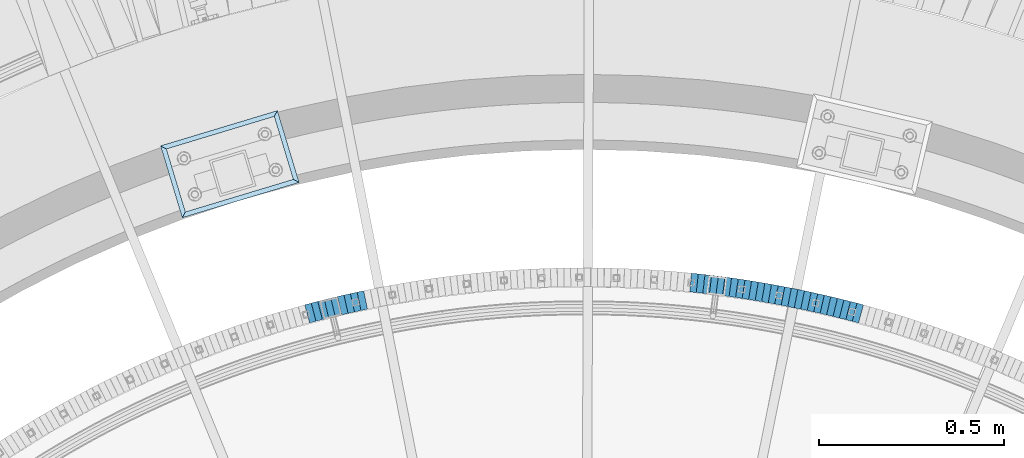
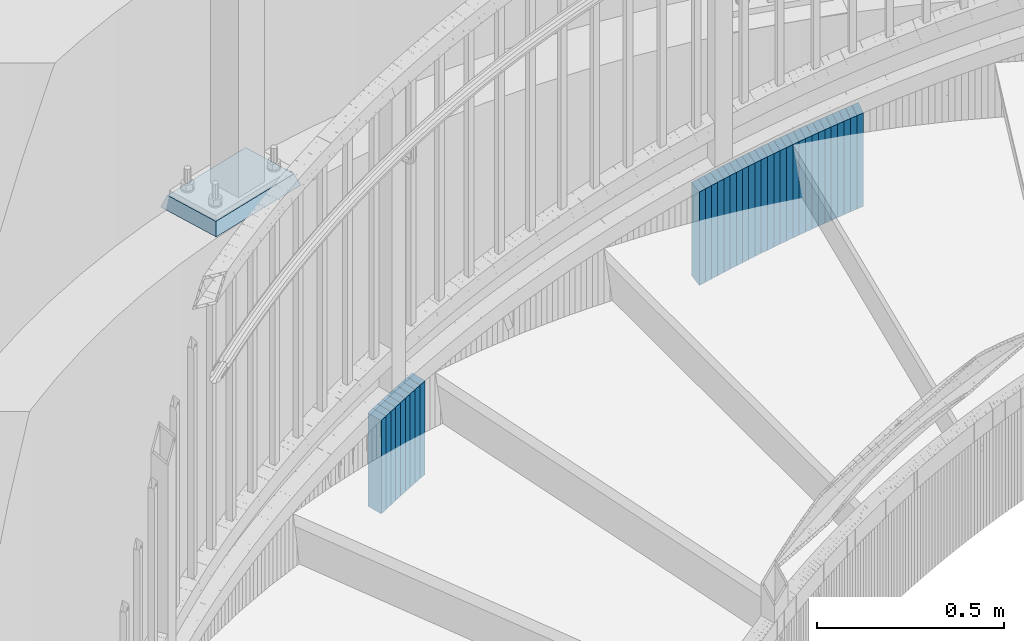
# One storey, part 917 of 975: 36 plates.
"""IFC2X3 building model written with IfcOpenShell, lengths in millimetres."""

from ifc_helpers import new_model, si_unit, frame, origin_with_axes, place, context, subcontext, project, spatial, faceted_brep, material, type_object, element, save


model = new_model("IFC2X3")

# Units and contexts
model_context = context("Model", 3, precision=1e-05, world=origin_with_axes())
body_context = subcontext(model_context, "Body", "Model", "MODEL_VIEW")
ifc_project = project(units=[si_unit("LENGTHUNIT", "METRE", prefix="MILLI"), si_unit("AREAUNIT", "SQUARE_METRE"), si_unit("VOLUMEUNIT", "CUBIC_METRE"), si_unit("MASSUNIT", "GRAM", prefix="KILO"), si_unit("TIMEUNIT", "SECOND"), si_unit("PLANEANGLEUNIT", "RADIAN"), si_unit("SOLIDANGLEUNIT", "STERADIAN"), si_unit("THERMODYNAMICTEMPERATUREUNIT", "DEGREE_CELSIUS"), si_unit("LUMINOUSINTENSITYUNIT", "LUMEN")], contexts=[model_context])

# Site, building, storey
site_placement = place(None, origin_with_axes())
site = spatial("IfcSite", under=ifc_project, at=site_placement, CompositionType="ELEMENT")
building_placement = place(site_placement, origin_with_axes())
building = spatial("IfcBuilding", under=site, at=building_placement, Name="Undefined", CompositionType="ELEMENT")
storey_placement = place(building_placement, origin_with_axes())
storey = spatial("IfcBuildingStorey", under=building, at=storey_placement, Name="Undefined", CompositionType="ELEMENT", Elevation=0.0)

# Plates
ifc_material_1 = material(Name="STEEL/A36")
plate_type_1 = type_object("IfcPlateType", PredefinedType="NOTDEFINED")
plate_1_placement = place(storey_placement, frame((35466.359514086, 6179.51815033245, 1301.99999999174), z_axis=(0.966048244824465, -0.258361739953056, 0.0), x_axis=(0.0, 0.0, -1.0)))
element("IfcPlate", 1, at=plate_1_placement, inside=storey, type_object=plate_type_1, material=ifc_material_1, Name="WALL", context=body_context, shape_type="Brep", body=[
    faceted_brep([(0.0, -25.3999999999724, -1.81898940354586e-11), (-5.69999980926514, -25.4000000000378, 17.8044929504049), (-5.69999980926514, 25.4000000000233, 17.8044929504613), (0.0, 25.3999999999869, 1.45519152283669e-11), (299.100006103516, -25.4000000000378, 17.8044929504049), (299.100006103516, 25.4000000000233, 17.8044929504613), (304.799987792969, -25.3999999999724, -1.81898940354586e-11), (304.799987792969, 25.3999999999869, 1.45519152283669e-11)], [[[0, 1, 2, 3]], [[1, 4, 5, 2]], [[4, 6, 7, 5]], [[6, 0, 3, 7]], [[5, 7, 3, 2]], [[6, 4, 1, 0]]]),
])
plate_2_placement = place(storey_placement, frame((35448.8912875998, 6184.06252434382, 1296.29999999174), z_axis=(0.967795253177515, -0.251738650046175, 0.0), x_axis=(0.0, 0.0, -1.0)))
element("IfcPlate", 2, at=plate_2_placement, inside=storey, type_object=plate_type_1, material=ifc_material_1, Name="WALL", context=body_context, shape_type="Brep", body=[
    faceted_brep([(0.0, -25.3999999999724, -1.81898940354586e-11), (-5.69999980926514, -25.4000000000233, 17.8807163238162), (-5.69999980926514, 25.400000000096, 17.8807163239253), (0.0, 25.3999999999869, 1.45519152283669e-11), (299.100006103516, -25.4000000000233, 17.8807163238162), (299.100006103516, 25.400000000096, 17.8807163239253), (304.799987792969, -25.3999999999724, -1.81898940354586e-11), (304.799987792969, 25.3999999999869, 1.45519152283669e-11)], [[[0, 1, 2, 3]], [[1, 4, 5, 2]], [[4, 6, 7, 5]], [[6, 0, 3, 7]], [[5, 7, 3, 2]], [[6, 4, 1, 0]]]),
])
plate_3_placement = place(storey_placement, frame((35431.1908193809, 6188.43872638545, 1290.49999999174), z_axis=(0.970795333552335, -0.23990919188937, 0.0), x_axis=(0.0, 0.0, -1.0)))
element("IfcPlate", 3, at=plate_3_placement, inside=storey, type_object=plate_type_1, material=ifc_material_1, Name="WALL", context=body_context, shape_type="Brep", body=[
    faceted_brep([(0.0, -25.3999999999724, -1.81898940354586e-11), (-5.80000019073486, -25.3999999999724, 17.9212169647508), (-5.80000019073486, 25.399999999885, 17.9212169646526), (0.0, 25.3999999999869, 1.45519152283669e-11), (299.0, -25.3999999999724, 17.9212169647508), (299.0, 25.399999999885, 17.9212169646526), (304.799987792969, -25.3999999999724, -1.81898940354586e-11), (304.799987792969, 25.3999999999869, 1.45519152283669e-11)], [[[0, 1, 2, 3]], [[1, 4, 5, 2]], [[4, 6, 7, 5]], [[6, 0, 3, 7]], [[5, 7, 3, 2]], [[6, 4, 1, 0]]]),
])
plate_4_placement = place(storey_placement, frame((35413.9239990979, 6192.73050310389, 1284.79999999174), z_axis=(0.970471582358486, -0.241215480089104, 0.0), x_axis=(0.0, 0.0, -1.0)))
element("IfcPlate", 4, at=plate_4_placement, inside=storey, type_object=plate_type_1, material=ifc_material_1, Name="WALL", context=body_context, shape_type="Brep", body=[
    faceted_brep([(0.0, -25.3999999999724, -1.81898940354586e-11), (-5.69999980926514, -25.4000000000524, 17.8331146239652), (-5.69999980926514, 25.4000000000742, 17.8331146240998), (0.0, 25.3999999999869, 1.45519152283669e-11), (299.100006103516, -25.4000000000524, 17.8331146239652), (299.100006103516, 25.4000000000742, 17.8331146240998), (304.799987792969, -25.3999999999724, -1.81898940354586e-11), (304.799987792969, 25.3999999999869, 1.45519152283669e-11)], [[[0, 1, 2, 3]], [[1, 4, 5, 2]], [[4, 6, 7, 5]], [[6, 0, 3, 7]], [[5, 7, 3, 2]], [[6, 4, 1, 0]]]),
])
plate_5_placement = place(storey_placement, frame((35396.3569954345, 6196.97141301187, 1279.09999999174), z_axis=(0.972082208620478, -0.234640532908391, 0.0), x_axis=(0.0, 0.0, -1.0)))
element("IfcPlate", 5, at=plate_5_placement, inside=storey, type_object=plate_type_1, material=ifc_material_1, Name="WALL", context=body_context, shape_type="Brep", body=[
    faceted_brep([(0.0, -25.3999999999724, -1.81898940354586e-11), (-5.69999980926514, -25.3999999999578, 17.9047489166387), (-5.69999980926514, 25.3999999999069, 17.9047489165732), (0.0, 25.3999999999869, 1.45519152283669e-11), (299.100006103516, -25.3999999999578, 17.9047489166387), (299.100006103516, 25.3999999999069, 17.9047489165732), (304.799987792969, -25.3999999999724, -1.81898940354586e-11), (304.799987792969, 25.3999999999869, 1.45519152283669e-11)], [[[0, 1, 2, 3]], [[1, 4, 5, 2]], [[4, 6, 7, 5]], [[6, 0, 3, 7]], [[5, 7, 3, 2]], [[6, 4, 1, 0]]]),
])
plate_6_placement = place(storey_placement, frame((35378.5568758462, 6201.04193098155, 1273.29999999174), z_axis=(0.974858506702201, -0.222824800931933, 0.0), x_axis=(0.0, 0.0, -1.0)))
element("IfcPlate", 6, at=plate_6_placement, inside=storey, type_object=plate_type_1, material=ifc_material_1, Name="WALL", context=body_context, shape_type="Brep", body=[
    faceted_brep([(0.0, -25.3999999999724, -1.81898940354586e-11), (-5.80000019073486, -25.4000000000196, 17.9513225554401), (-5.80000019073486, 25.3999999999851, 17.9513225555565), (0.0, 25.3999999999869, 1.45519152283669e-11), (299.0, -25.4000000000196, 17.9513225554401), (299.0, 25.3999999999851, 17.9513225555565), (304.799987792969, -25.3999999999724, -1.81898940354586e-11), (304.799987792969, 25.3999999999869, 1.45519152283669e-11)], [[[0, 1, 2, 3]], [[1, 4, 5, 2]], [[4, 6, 7, 5]], [[6, 0, 3, 7]], [[5, 7, 3, 2]], [[6, 4, 1, 0]]]),
])
plate_7_placement = place(storey_placement, frame((35361.0523969051, 6204.96558016644, 1267.59999999174), z_axis=(0.975789576997609, -0.218711456999464, 0.0), x_axis=(0.0, 0.0, -1.0)))
element("IfcPlate", 7, at=plate_7_placement, inside=storey, type_object=plate_type_1, material=ifc_material_1, Name="WALL", context=body_context, shape_type="Brep", body=[
    faceted_brep([(0.0, -25.3999999999724, -1.81898940354586e-11), (-5.69999980926514, -25.4000000000524, 17.8331146239652), (-5.69999980926514, 25.4000000000742, 17.8331146240998), (0.0, 25.3999999999869, 1.45519152283669e-11), (299.100006103516, -25.4000000000524, 17.8331146239652), (299.100006103516, 25.4000000000742, 17.8331146240998), (304.799987792969, -25.3999999999724, -1.81898940354586e-11), (304.799987792969, 25.3999999999869, 1.45519152283669e-11)], [[[0, 1, 2, 3]], [[1, 4, 5, 2]], [[4, 6, 7, 5]], [[6, 0, 3, 7]], [[5, 7, 3, 2]], [[6, 4, 1, 0]]]),
])
plate_8_placement = place(storey_placement, frame((35343.5221586185, 6208.87233834774, 1261.79999999174), z_axis=(0.976055647129105, -0.217520973028771, 0.0), x_axis=(0.0, 0.0, -1.0)))
element("IfcPlate", 8, at=plate_8_placement, inside=storey, type_object=plate_type_1, material=ifc_material_1, Name="WALL", context=body_context, shape_type="Brep", body=[
    faceted_brep([(0.0, -25.3999999999724, -1.81898940354586e-11), (-5.80000019073486, -25.3999999998778, 17.9254016876821), (-5.80000019073486, 25.3999999999651, 17.9254016876057), (0.0, 25.3999999999869, 1.45519152283669e-11), (299.0, -25.3999999998778, 17.9254016876821), (299.0, 25.3999999999651, 17.9254016876057), (304.799987792969, -25.3999999999724, -1.81898940354586e-11), (304.799987792969, 25.3999999999869, 1.45519152283669e-11)], [[[0, 1, 2, 3]], [[1, 4, 5, 2]], [[4, 6, 7, 5]], [[6, 0, 3, 7]], [[5, 7, 3, 2]], [[6, 4, 1, 0]]]),
])
plate_9_placement = place(storey_placement, frame((35325.6226741571, 6212.63718690472, 1256.09999999174), z_axis=(0.978608739939518, -0.205730245987284, 0.0), x_axis=(0.0, 0.0, -1.0)))
element("IfcPlate", 9, at=plate_9_placement, inside=storey, type_object=plate_type_1, material=ifc_material_1, Name="WALL", context=body_context, shape_type="Brep", body=[
    faceted_brep([(0.0, -25.3999999999724, -1.81898940354586e-11), (-5.69999980926514, -25.3999999999141, 17.9836044311924), (-5.69999980926514, 25.3999999999432, 17.983604431116), (0.0, 25.3999999999869, 1.45519152283669e-11), (299.100006103516, -25.3999999999141, 17.9836044311924), (299.100006103516, 25.3999999999432, 17.983604431116), (304.799987792969, -25.3999999999724, -1.81898940354586e-11), (304.799987792969, 25.3999999999869, 1.45519152283669e-11)], [[[0, 1, 2, 3]], [[1, 4, 5, 2]], [[4, 6, 7, 5]], [[6, 0, 3, 7]], [[5, 7, 3, 2]], [[6, 4, 1, 0]]]),
])
plate_10_placement = place(storey_placement, frame((35308.0150987024, 6216.25955934488, 1250.39999999174), z_axis=(0.979489544723104, -0.201494991943039, 0.0), x_axis=(0.0, 0.0, -1.0)))
element("IfcPlate", 10, at=plate_10_placement, inside=storey, type_object=plate_type_1, material=ifc_material_1, Name="WALL", context=body_context, shape_type="Brep", body=[
    faceted_brep([(0.0, -25.3999999999724, -1.81898940354586e-11), (-5.69999980926514, -25.4000000000524, 17.8734436034756), (-5.69999980926514, 25.4000000000888, 17.8734436035884), (0.0, 25.3999999999869, 1.45519152283669e-11), (299.100006103516, -25.4000000000524, 17.8734436034756), (299.100006103516, 25.4000000000888, 17.8734436035884), (304.799987792969, -25.3999999999724, -1.81898940354586e-11), (304.799987792969, 25.3999999999869, 1.45519152283669e-11)], [[[0, 1, 2, 3]], [[1, 4, 5, 2]], [[4, 6, 7, 5]], [[6, 0, 3, 7]], [[5, 7, 3, 2]], [[6, 4, 1, 0]]]),
])
plate_11_placement = place(storey_placement, frame((35290.2512522868, 6219.79270328996, 1244.59999999174), z_axis=(0.980794424500948, -0.195044345900756, 0.0), x_axis=(0.0, 0.0, -1.0)))
element("IfcPlate", 11, at=plate_11_placement, inside=storey, type_object=plate_type_1, material=ifc_material_1, Name="WALL", context=body_context, shape_type="Brep", body=[
    faceted_brep([(0.0, -25.3999999999724, -1.81898940354586e-11), (-5.80000019073486, -25.3999999999869, 17.9387855530222), (-5.80000019073486, 25.3999999999469, 17.9387855528548), (0.0, 25.3999999999869, 1.45519152283669e-11), (299.0, -25.3999999999869, 17.9387855530222), (299.0, 25.3999999999469, 17.9387855528548), (304.799987792969, -25.3999999999724, -1.81898940354586e-11), (304.799987792969, 25.3999999999869, 1.45519152283669e-11)], [[[0, 1, 2, 3]], [[1, 4, 5, 2]], [[4, 6, 7, 5]], [[6, 0, 3, 7]], [[5, 7, 3, 2]], [[6, 4, 1, 0]]]),
])
plate_12_placement = place(storey_placement, frame((35272.5148702956, 6223.21943705456, 1238.79999999174), z_axis=(0.98184693485788, -0.189674975972545, 0.0), x_axis=(0.0, 0.0, -1.0)))
element("IfcPlate", 12, at=plate_12_placement, inside=storey, type_object=plate_type_1, material=ifc_material_1, Name="WALL", context=body_context, shape_type="Brep", body=[
    faceted_brep([(0.0, -25.3999999999724, -1.81898940354586e-11), (-5.80000019073486, -25.3999999998778, 17.9254016876821), (-5.80000019073486, 25.3999999999651, 17.9254016876057), (0.0, 25.3999999999869, 1.45519152283669e-11), (299.0, -25.3999999998778, 17.9254016876821), (299.0, 25.3999999999651, 17.9254016876057), (304.799987792969, -25.3999999999724, -1.81898940354586e-11), (304.799987792969, 25.3999999999869, 1.45519152283669e-11)], [[[0, 1, 2, 3]], [[1, 4, 5, 2]], [[4, 6, 7, 5]], [[6, 0, 3, 7]], [[5, 7, 3, 2]], [[6, 4, 1, 0]]]),
])
plate_13_placement = place(storey_placement, frame((35254.9148703005, 6226.61943705608, 1233.09999999174), z_axis=(0.98184693485788, -0.189674975972545, 0.0), x_axis=(0.0, 0.0, -1.0)))
element("IfcPlate", 13, at=plate_13_placement, inside=storey, type_object=plate_type_1, material=ifc_material_1, Name="WALL", context=body_context, shape_type="Brep", body=[
    faceted_brep([(0.0, -25.3999999999724, -1.81898940354586e-11), (-5.69999980926514, -25.3999999999942, 17.9287471771386), (-5.69999980926514, 25.3999999999796, 17.9287471770876), (0.0, 25.3999999999869, 1.45519152283669e-11), (299.100006103516, -25.3999999999942, 17.9287471771386), (299.100006103516, 25.3999999999796, 17.9287471770876), (304.799987792969, -25.3999999999724, -1.81898940354586e-11), (304.799987792969, 25.3999999999869, 1.45519152283669e-11)], [[[0, 1, 2, 3]], [[1, 4, 5, 2]], [[4, 6, 7, 5]], [[6, 0, 3, 7]], [[5, 7, 3, 2]], [[6, 4, 1, 0]]]),
])
plate_14_placement = place(storey_placement, frame((35237.040816045, 6229.87082062702, 1227.39999999174), z_axis=(0.983869910131907, -0.178885438023984, 0.0), x_axis=(0.0, 0.0, -1.0)))
element("IfcPlate", 14, at=plate_14_placement, inside=storey, type_object=plate_type_1, material=ifc_material_1, Name="WALL", context=body_context, shape_type="Brep", body=[
    faceted_brep([(0.0, -25.3999999999724, -1.81898940354586e-11), (-5.69999980926514, -25.4000000000087, 17.8910598754701), (-5.69999980926514, 25.4000000000087, 17.8910598755028), (0.0, 25.3999999999869, 1.45519152283669e-11), (299.100006103516, -25.4000000000087, 17.8910598754701), (299.100006103516, 25.4000000000087, 17.8910598755028), (304.799987792969, -25.3999999999724, -1.81898940354586e-11), (304.799987792969, 25.3999999999869, 1.45519152283669e-11)], [[[0, 1, 2, 3]], [[1, 4, 5, 2]], [[4, 6, 7, 5]], [[6, 0, 3, 7]], [[5, 7, 3, 2]], [[6, 4, 1, 0]]]),
])
plate_15_placement = place(storey_placement, frame((35219.1790150726, 6232.9996985061, 1221.59999999174), z_axis=(0.985006834489333, -0.172515321085703, 0.0), x_axis=(0.0, 0.0, -1.0)))
element("IfcPlate", 15, at=plate_15_placement, inside=storey, type_object=plate_type_1, material=ifc_material_1, Name="WALL", context=body_context, shape_type="Brep", body=[
    faceted_brep([(0.0, -25.3999999999724, -1.81898940354586e-11), (-5.80000019073486, -25.4000000000051, 17.9724788665662), (-5.80000019073486, 25.4000000000196, 17.9724788666281), (0.0, 25.3999999999869, 1.45519152283669e-11), (299.0, -25.4000000000051, 17.9724788665662), (299.0, 25.4000000000196, 17.9724788666281), (304.799987792969, -25.3999999999724, -1.81898940354586e-11), (304.799987792969, 25.3999999999869, 1.45519152283669e-11)], [[[0, 1, 2, 3]], [[1, 4, 5, 2]], [[4, 6, 7, 5]], [[6, 0, 3, 7]], [[5, 7, 3, 2]], [[6, 4, 1, 0]]]),
])
plate_16_placement = place(storey_placement, frame((35201.4651126618, 6236.01938049812, 1215.89999999174), z_axis=(0.985781716087097, -0.168030974014847, 0.0), x_axis=(0.0, 0.0, -1.0)))
element("IfcPlate", 16, at=plate_16_placement, inside=storey, type_object=plate_type_1, material=ifc_material_1, Name="WALL", context=body_context, shape_type="Brep", body=[
    faceted_brep([(0.0, -25.3999999999724, -1.81898940354586e-11), (-5.69999980926514, -25.3999999999578, 17.853290557905), (-5.69999980926514, 25.4000000000124, 17.8532905578759), (0.0, 25.3999999999869, 1.45519152283669e-11), (299.100006103516, -25.3999999999578, 17.853290557905), (299.100006103516, 25.4000000000124, 17.8532905578759), (304.799987792969, -25.3999999999724, -1.81898940354586e-11), (304.799987792969, 25.3999999999869, 1.45519152283669e-11)], [[[0, 1, 2, 3]], [[1, 4, 5, 2]], [[4, 6, 7, 5]], [[6, 0, 3, 7]], [[5, 7, 3, 2]], [[6, 4, 1, 0]]]),
])
plate_17_placement = place(storey_placement, frame((35183.6039508099, 6238.94631812282, 1210.09999999174), z_axis=(0.986842252457648, -0.161686019074982, 0.0), x_axis=(0.0, 0.0, -1.0)))
element("IfcPlate", 17, at=plate_17_placement, inside=storey, type_object=plate_type_1, material=ifc_material_1, Name="WALL", context=body_context, shape_type="Brep", body=[
    faceted_brep([(0.0, -25.3999999999724, -1.81898940354586e-11), (-5.80000019073486, -25.3999999999869, 17.9387855530222), (-5.80000019073486, 25.3999999999469, 17.9387855528548), (0.0, 25.3999999999869, 1.45519152283669e-11), (299.0, -25.3999999999869, 17.9387855530222), (299.0, 25.3999999999469, 17.9387855528548), (304.799987792969, -25.3999999999724, -1.81898940354586e-11), (304.799987792969, 25.3999999999869, 1.45519152283669e-11)], [[[0, 1, 2, 3]], [[1, 4, 5, 2]], [[4, 6, 7, 5]], [[6, 0, 3, 7]], [[5, 7, 3, 2]], [[6, 4, 1, 0]]]),
])
plate_18_placement = place(storey_placement, frame((35165.7486587391, 6241.68681286783, 1204.39999999174), z_axis=(0.98843653377194, -0.151635149965013, 0.0), x_axis=(0.0, 0.0, -1.0)))
element("IfcPlate", 18, at=plate_18_placement, inside=storey, type_object=plate_type_1, material=ifc_material_1, Name="WALL", context=body_context, shape_type="Brep", body=[
    faceted_brep([(0.0, -25.3999999999724, -1.81898940354586e-11), (-5.69999980926514, -25.4000000001106, 17.8134784697704), (-5.69999980926514, 25.4000000000306, 17.8134784698614), (0.0, 25.3999999999869, 1.45519152283669e-11), (299.100006103516, -25.4000000001106, 17.8134784697704), (299.100006103516, 25.4000000000306, 17.8134784698614), (304.799987792969, -25.3999999999724, -1.81898940354586e-11), (304.799987792969, 25.3999999999869, 1.45519152283669e-11)], [[[0, 1, 2, 3]], [[1, 4, 5, 2]], [[4, 6, 7, 5]], [[6, 0, 3, 7]], [[5, 7, 3, 2]], [[6, 4, 1, 0]]]),
])
plate_19_placement = place(storey_placement, frame((35148.0273948682, 6244.39006572194, 1198.69999999174), z_axis=(0.988564598909017, -0.150797989986122, 0.0), x_axis=(0.0, 0.0, -1.0)))
element("IfcPlate", 19, at=plate_19_placement, inside=storey, type_object=plate_type_1, material=ifc_material_1, Name="WALL", context=body_context, shape_type="Brep", body=[
    faceted_brep([(0.0, -25.3999999999724, -1.81898940354586e-11), (-5.69999980926514, -25.3999999999578, 17.9047489166387), (-5.69999980926514, 25.3999999999069, 17.9047489165732), (0.0, 25.3999999999869, 1.45519152283669e-11), (299.100006103516, -25.3999999999578, 17.9047489166387), (299.100006103516, 25.3999999999069, 17.9047489165732), (304.799987792969, -25.3999999999724, -1.81898940354586e-11), (304.799987792969, 25.3999999999869, 1.45519152283669e-11)], [[[0, 1, 2, 3]], [[1, 4, 5, 2]], [[4, 6, 7, 5]], [[6, 0, 3, 7]], [[5, 7, 3, 2]], [[6, 4, 1, 0]]]),
])
plate_20_placement = place(storey_placement, frame((35130.0494379654, 6246.93089427229, 1192.89999999174), z_axis=(0.990172022181619, -0.139854805025652, 0.0), x_axis=(0.0, 0.0, -1.0)))
element("IfcPlate", 20, at=plate_20_placement, inside=storey, type_object=plate_type_1, material=ifc_material_1, Name="WALL", context=body_context, shape_type="Brep", body=[
    faceted_brep([(0.0, -25.3999999999724, -1.81898940354586e-11), (-5.80000019073486, -25.4000000000415, 17.8751220702761), (-5.80000019073486, 25.4000000000015, 17.8751220703089), (0.0, 25.3999999999869, 1.45519152283669e-11), (299.0, -25.4000000000415, 17.8751220702761), (299.0, 25.4000000000015, 17.8751220703089), (304.799987792969, -25.3999999999724, -1.81898940354586e-11), (304.799987792969, 25.3999999999869, 1.45519152283669e-11)], [[[0, 1, 2, 3]], [[1, 4, 5, 2]], [[4, 6, 7, 5]], [[6, 0, 3, 7]], [[5, 7, 3, 2]], [[6, 4, 1, 0]]]),
])
plate_21_placement = place(storey_placement, frame((35112.2099632015, 6249.35019994797, 1187.19999999174), z_axis=(0.990932088173368, -0.134363673023508, 0.0), x_axis=(0.0, 0.0, -1.0)))
element("IfcPlate", 21, at=plate_21_placement, inside=storey, type_object=plate_type_1, material=ifc_material_1, Name="WALL", context=body_context, shape_type="Brep", body=[
    faceted_brep([(0.0, -25.3999999999724, -1.81898940354586e-11), (-5.69999980926514, -25.3999999999687, 17.8619709015074), (-5.69999980926514, 25.4000000000415, 17.8619709015402), (0.0, 25.3999999999869, 1.45519152283669e-11), (299.100006103516, -25.3999999999687, 17.8619709015074), (299.100006103516, 25.4000000000415, 17.8619709015402), (304.799987792969, -25.3999999999724, -1.81898940354586e-11), (304.799987792969, 25.3999999999869, 1.45519152283669e-11)], [[[0, 1, 2, 3]], [[1, 4, 5, 2]], [[4, 6, 7, 5]], [[6, 0, 3, 7]], [[5, 7, 3, 2]], [[6, 4, 1, 0]]]),
])
plate_22_placement = place(storey_placement, frame((35094.3701733448, 6251.6687594735, 1181.49999999174), z_axis=(0.991662778167147, -0.128860135021719, 0.0), x_axis=(0.0, 0.0, -1.0)))
element("IfcPlate", 22, at=plate_22_placement, inside=storey, type_object=plate_type_1, material=ifc_material_1, Name="WALL", context=body_context, shape_type="Brep", body=[
    faceted_brep([(0.0, -25.3999999999724, -1.81898940354586e-11), (-5.69999980926514, -25.3999999999578, 17.853290557905), (-5.69999980926514, 25.4000000000124, 17.8532905578759), (0.0, 25.3999999999869, 1.45519152283669e-11), (299.100006103516, -25.3999999999578, 17.853290557905), (299.100006103516, 25.4000000000124, 17.8532905578759), (304.799987792969, -25.3999999999724, -1.81898940354586e-11), (304.799987792969, 25.3999999999869, 1.45519152283669e-11)], [[[0, 1, 2, 3]], [[1, 4, 5, 2]], [[4, 6, 7, 5]], [[6, 0, 3, 7]], [[5, 7, 3, 2]], [[6, 4, 1, 0]]]),
])
plate_23_placement = place(storey_placement, frame((35076.5300804051, 6253.88656775912, 1175.69999999174), z_axis=(0.992363891737346, -0.123344664967353, 0.0), x_axis=(0.0, 0.0, -1.0)))
element("IfcPlate", 23, at=plate_23_placement, inside=storey, type_object=plate_type_1, material=ifc_material_1, Name="WALL", context=body_context, shape_type="Brep", body=[
    faceted_brep([(0.0, -25.3999999999724, -1.81898940354586e-11), (-5.80000019073486, -25.3999999999578, 17.8370399475461), (-5.80000019073486, 25.4000000000524, 17.8370399475607), (0.0, 25.3999999999869, 1.45519152283669e-11), (299.0, -25.3999999999578, 17.8370399475461), (299.0, 25.4000000000524, 17.8370399475607), (304.799987792969, -25.3999999999724, -1.81898940354586e-11), (304.799987792969, 25.3999999999869, 1.45519152283669e-11)], [[[0, 1, 2, 3]], [[1, 4, 5, 2]], [[4, 6, 7, 5]], [[6, 0, 3, 7]], [[5, 7, 3, 2]], [[6, 4, 1, 0]]]),
])
plate_24_placement = place(storey_placement, frame((35058.5731157521, 6256.00558158949, 1169.99999999174), z_axis=(0.993112467730433, -0.117164953968197, 0.0), x_axis=(0.0, 0.0, -1.0)))
element("IfcPlate", 24, at=plate_24_placement, inside=storey, type_object=plate_type_1, material=ifc_material_1, Name="WALL", context=body_context, shape_type="Brep", body=[
    faceted_brep([(0.0, -25.3999999999724, -1.81898940354586e-11), (-5.69999980926514, -25.4000000000087, 17.9245643615468), (-5.69999980926514, 25.3999999999687, 17.9245643615541), (0.0, 25.3999999999869, 1.45519152283669e-11), (299.100006103516, -25.4000000000087, 17.9245643615468), (299.100006103516, 25.3999999999687, 17.9245643615541), (304.799987792969, -25.3999999999724, -1.81898940354586e-11), (304.799987792969, 25.3999999999869, 1.45519152283669e-11)], [[[0, 1, 2, 3]], [[1, 4, 5, 2]], [[4, 6, 7, 5]], [[6, 0, 3, 7]], [[5, 7, 3, 2]], [[6, 4, 1, 0]]]),
])
plate_25_placement = place(storey_placement, frame((35040.6081051982, 6257.93543712971, 1164.29999999174), z_axis=(0.99428788273052, -0.106731467971073, 0.0), x_axis=(0.0, 0.0, -1.0)))
element("IfcPlate", 25, at=plate_25_placement, inside=storey, type_object=plate_type_1, material=ifc_material_1, Name="WALL", context=body_context, shape_type="Brep", body=[
    faceted_brep([(0.0, -25.3999999999724, -1.81898940354586e-11), (-5.69999980926514, -25.4000000000378, 17.8044929504049), (-5.69999980926514, 25.4000000000233, 17.8044929504613), (0.0, 25.3999999999869, 1.45519152283669e-11), (299.100006103516, -25.4000000000378, 17.8044929504049), (299.100006103516, 25.4000000000233, 17.8044929504613), (304.799987792969, -25.3999999999724, -1.81898940354586e-11), (304.799987792969, 25.3999999999869, 1.45519152283669e-11)], [[[0, 1, 2, 3]], [[1, 4, 5, 2]], [[4, 6, 7, 5]], [[6, 0, 3, 7]], [[5, 7, 3, 2]], [[6, 4, 1, 0]]]),
])
plate_26_placement = place(storey_placement, frame((35022.7930470006, 6259.83704900326, 1158.59999999174), z_axis=(0.994351342364744, -0.106138626038932, 0.0), x_axis=(0.0, 0.0, -1.0)))
element("IfcPlate", 26, at=plate_26_placement, inside=storey, type_object=plate_type_1, material=ifc_material_1, Name="WALL", context=body_context, shape_type="Brep", body=[
    faceted_brep([(0.0, -25.3999999999724, -1.81898940354586e-11), (-5.69999980926514, -25.3999999999578, 17.9047489166387), (-5.69999980926514, 25.3999999999069, 17.9047489165732), (0.0, 25.3999999999869, 1.45519152283669e-11), (299.100006103516, -25.3999999999578, 17.9047489166387), (299.100006103516, 25.3999999999069, 17.9047489165732), (304.799987792969, -25.3999999999724, -1.81898940354586e-11), (304.799987792969, 25.3999999999869, 1.45519152283669e-11)], [[[0, 1, 2, 3]], [[1, 4, 5, 2]], [[4, 6, 7, 5]], [[6, 0, 3, 7]], [[5, 7, 3, 2]], [[6, 4, 1, 0]]]),
])
plate_27_placement = place(storey_placement, frame((34125.6715776473, 6208.93718689176, 871.799999991737), z_axis=(0.978608739939518, 0.205730245987284, 0.0), x_axis=(0.0, 0.0, -1.0)))
element("IfcPlate", 27, at=plate_27_placement, inside=storey, type_object=plate_type_1, material=ifc_material_1, Name="WALL", context=body_context, shape_type="Brep", body=[
    faceted_brep([(0.0, -25.3999999999724, -1.81898940354586e-11), (-5.69999980926514, -25.3999999999141, 17.9836044311924), (-5.69999980926514, 25.3999999999432, 17.983604431116), (0.0, 25.3999999999869, 1.45519152283669e-11), (299.100006103516, -25.3999999999141, 17.9836044311924), (299.100006103516, 25.3999999999432, 17.983604431116), (304.799987792969, -25.3999999999724, -1.81898940354586e-11), (304.799987792969, 25.3999999999869, 1.45519152283669e-11)], [[[0, 1, 2, 3]], [[1, 4, 5, 2]], [[4, 6, 7, 5]], [[6, 0, 3, 7]], [[5, 7, 3, 2]], [[6, 4, 1, 0]]]),
])
plate_28_placement = place(storey_placement, frame((34107.872093185, 6204.97233833447, 865.999999991737), z_axis=(0.976055647129105, 0.217520973028771, 0.0), x_axis=(0.0, 0.0, -1.0)))
element("IfcPlate", 28, at=plate_28_placement, inside=storey, type_object=plate_type_1, material=ifc_material_1, Name="WALL", context=body_context, shape_type="Brep", body=[
    faceted_brep([(0.0, -25.3999999999724, -1.81898940354586e-11), (-5.80000019073486, -25.3999999998778, 17.9254016876821), (-5.80000019073486, 25.3999999999651, 17.9254016876057), (0.0, 25.3999999999869, 1.45519152283669e-11), (299.0, -25.3999999998778, 17.9254016876821), (299.0, 25.3999999999651, 17.9254016876057), (304.799987792969, -25.3999999999724, -1.81898940354586e-11), (304.799987792969, 25.3999999999869, 1.45519152283669e-11)], [[[0, 1, 2, 3]], [[1, 4, 5, 2]], [[4, 6, 7, 5]], [[6, 0, 3, 7]], [[5, 7, 3, 2]], [[6, 4, 1, 0]]]),
])
plate_29_placement = place(storey_placement, frame((34090.4418548967, 6201.0655801527, 860.299999991737), z_axis=(0.975789576997609, 0.218711456999464, 0.0), x_axis=(0.0, 0.0, -1.0)))
element("IfcPlate", 29, at=plate_29_placement, inside=storey, type_object=plate_type_1, material=ifc_material_1, Name="WALL", context=body_context, shape_type="Brep", body=[
    faceted_brep([(0.0, -25.3999999999724, -1.81898940354586e-11), (-5.69999980926514, -25.4000000000524, 17.8331146239652), (-5.69999980926514, 25.4000000000742, 17.8331146240998), (0.0, 25.3999999999869, 1.45519152283669e-11), (299.100006103516, -25.4000000000524, 17.8331146239652), (299.100006103516, 25.4000000000742, 17.8331146240998), (304.799987792969, -25.3999999999724, -1.81898940354586e-11), (304.799987792969, 25.3999999999869, 1.45519152283669e-11)], [[[0, 1, 2, 3]], [[1, 4, 5, 2]], [[4, 6, 7, 5]], [[6, 0, 3, 7]], [[5, 7, 3, 2]], [[6, 4, 1, 0]]]),
])
plate_30_placement = place(storey_placement, frame((34072.906476908, 6197.03484803447, 854.499999991737), z_axis=(0.974579651097025, 0.224041299022305, 0.0), x_axis=(0.0, 0.0, -1.0)))
element("IfcPlate", 30, at=plate_30_placement, inside=storey, type_object=plate_type_1, material=ifc_material_1, Name="WALL", context=body_context, shape_type="Brep", body=[
    faceted_brep([(0.0, -25.3999999999724, -1.81898940354586e-11), (-5.80000019073486, -25.3999999999869, 17.8549709320232), (-5.80000019073486, 25.3999999999432, 17.8549709319796), (0.0, 25.3999999999869, 1.45519152283669e-11), (299.0, -25.3999999999869, 17.8549709320232), (299.0, 25.3999999999432, 17.8549709319796), (304.799987792969, -25.3999999999724, -1.81898940354586e-11), (304.799987792969, 25.3999999999869, 1.45519152283669e-11)], [[[0, 1, 2, 3]], [[1, 4, 5, 2]], [[4, 6, 7, 5]], [[6, 0, 3, 7]], [[5, 7, 3, 2]], [[6, 4, 1, 0]]]),
])
plate_31_placement = place(storey_placement, frame((34055.2372563753, 6192.77141299521, 848.799999991737), z_axis=(0.972082208620478, 0.234640532908391, 0.0), x_axis=(0.0, 0.0, -1.0)))
element("IfcPlate", 31, at=plate_31_placement, inside=storey, type_object=plate_type_1, material=ifc_material_1, Name="WALL", context=body_context, shape_type="Brep", body=[
    faceted_brep([(0.0, -25.3999999999724, -1.81898940354586e-11), (-5.69999980926514, -25.3999999999578, 17.9047489166387), (-5.69999980926514, 25.3999999999069, 17.9047489165732), (0.0, 25.3999999999869, 1.45519152283669e-11), (299.100006103516, -25.3999999999578, 17.9047489166387), (299.100006103516, 25.3999999999069, 17.9047489165732), (304.799987792969, -25.3999999999724, -1.81898940354586e-11), (304.799987792969, 25.3999999999869, 1.45519152283669e-11)], [[[0, 1, 2, 3]], [[1, 4, 5, 2]], [[4, 6, 7, 5]], [[6, 0, 3, 7]], [[5, 7, 3, 2]], [[6, 4, 1, 0]]]),
])
plate_32_placement = place(storey_placement, frame((34037.7034324349, 6188.43872636963, 843.099999991737), z_axis=(0.970795333552335, 0.23990919188937, 0.0), x_axis=(0.0, 0.0, -1.0)))
element("IfcPlate", 32, at=plate_32_placement, inside=storey, type_object=plate_type_1, material=ifc_material_1, Name="WALL", context=body_context, shape_type="Brep", body=[
    faceted_brep([(0.0, -25.3999999999724, -1.81898940354586e-11), (-5.69999980926514, -25.4000000000087, 17.9245643615468), (-5.69999980926514, 25.3999999999687, 17.9245643615541), (0.0, 25.3999999999869, 1.45519152283669e-11), (299.100006103516, -25.4000000000087, 17.9245643615468), (299.100006103516, 25.3999999999687, 17.9245643615541), (304.799987792969, -25.3999999999724, -1.81898940354586e-11), (304.799987792969, 25.3999999999869, 1.45519152283669e-11)], [[[0, 1, 2, 3]], [[1, 4, 5, 2]], [[4, 6, 7, 5]], [[6, 0, 3, 7]], [[5, 7, 3, 2]], [[6, 4, 1, 0]]]),
])
plate_33_placement = place(storey_placement, frame((34020.3702527217, 6184.13050309059, 837.299999991737), z_axis=(0.970471582358486, 0.241215480089104, 0.0), x_axis=(0.0, 0.0, -1.0)))
element("IfcPlate", 33, at=plate_33_placement, inside=storey, type_object=plate_type_1, material=ifc_material_1, Name="WALL", context=body_context, shape_type="Brep", body=[
    faceted_brep([(0.0, -25.3999999999724, -1.81898940354586e-11), (-5.80000019073486, -25.4000000000078, 17.8305912018768), (-5.80000019073486, 25.4000000000042, 17.8305912017677), (0.0, 25.3999999999869, 1.45519152283669e-11), (299.0, -25.4000000000078, 17.8305912018768), (299.0, 25.4000000000042, 17.8305912017677), (304.799987792969, -25.3999999999724, -1.81898940354586e-11), (304.799987792969, 25.3999999999869, 1.45519152283669e-11)], [[[0, 1, 2, 3]], [[1, 4, 5, 2]], [[4, 6, 7, 5]], [[6, 0, 3, 7]], [[5, 7, 3, 2]], [[6, 4, 1, 0]]]),
])
plate_34_placement = place(storey_placement, frame((34002.8029642025, 6179.56252432899, 831.599999991737), z_axis=(0.967795253177515, 0.251738650046175, 0.0), x_axis=(0.0, 0.0, -1.0)))
element("IfcPlate", 34, at=plate_34_placement, inside=storey, type_object=plate_type_1, material=ifc_material_1, Name="WALL", context=body_context, shape_type="Brep", body=[
    faceted_brep([(0.0, -25.3999999999724, -1.81898940354586e-11), (-5.69999980926514, -25.4000000000233, 17.8807163238162), (-5.69999980926514, 25.400000000096, 17.8807163239253), (0.0, 25.3999999999869, 1.45519152283669e-11), (299.100006103516, -25.4000000000233, 17.8807163238162), (299.100006103516, 25.400000000096, 17.8807163239253), (304.799987792969, -25.3999999999724, -1.81898940354586e-11), (304.799987792969, 25.3999999999869, 1.45519152283669e-11)], [[[0, 1, 2, 3]], [[1, 4, 5, 2]], [[4, 6, 7, 5]], [[6, 0, 3, 7]], [[5, 7, 3, 2]], [[6, 4, 1, 0]]]),
])
plate_35_placement = place(storey_placement, frame((33985.37015901, 6174.92759606855, 825.899999991737), z_axis=(0.966420124809233, 0.256967200949276, 0.0), x_axis=(0.0, 0.0, -1.0)))
element("IfcPlate", 35, at=plate_35_placement, inside=storey, type_object=plate_type_1, material=ifc_material_1, Name="WALL", context=body_context, shape_type="Brep", body=[
    faceted_brep([(0.0, -25.3999999999724, -1.81898940354586e-11), (-5.69999980926514, -25.3999999999578, 17.9047489166387), (-5.69999980926514, 25.3999999999069, 17.9047489165732), (0.0, 25.3999999999869, 1.45519152283669e-11), (299.100006103516, -25.3999999999578, 17.9047489166387), (299.100006103516, 25.3999999999069, 17.9047489165732), (304.799987792969, -25.3999999999724, -1.81898940354586e-11), (304.799987792969, 25.3999999999869, 1.45519152283669e-11)], [[[0, 1, 2, 3]], [[1, 4, 5, 2]], [[4, 6, 7, 5]], [[6, 0, 3, 7]], [[5, 7, 3, 2]], [[6, 4, 1, 0]]]),
])
ifc_material_2 = material(Name="CONCRETE/GROUT")
plate_type_2 = type_object("IfcPlateType", PredefinedType="NOTDEFINED")
plate_36_placement = place(storey_placement, frame((33647.369883685, 6435.07340343173, 1390.65), z_axis=(-0.288864709123643, 0.957369928409553, 0.0), x_axis=(0.957369928409554, 0.288864709123642, 0.0)))
element("IfcPlate", 36, at=plate_36_placement, inside=storey, type_object=plate_type_2, material=ifc_material_2, Name="GROUT", context=body_context, shape_type="Brep", body=[
    faceted_brep([(330.200012367033, 19.0500013667977, 203.199997417756), (1.09139364212751e-11, 19.05, 203.199996948282), (12.7000000020234, -19.0499999844749, 190.500000003405), (317.500000003602, -19.049999999379, 190.499999996773), (330.200012206657, 19.0500004884277, -1.48389517562464e-07), (317.499999999585, -19.0499999999586, 12.6999999966938), (12.6999999980108, -19.0499999989649, 12.7000000033258), (2.63382389675826e-07, 19.0500000000138, 0.0)], [[[0, 1, 2, 3]], [[4, 5, 6, 7]], [[5, 4, 0, 3]], [[6, 5, 3, 2]], [[7, 6, 2, 1]], [[4, 7, 1, 0]]]),
])

save(model, "model.ifc")
